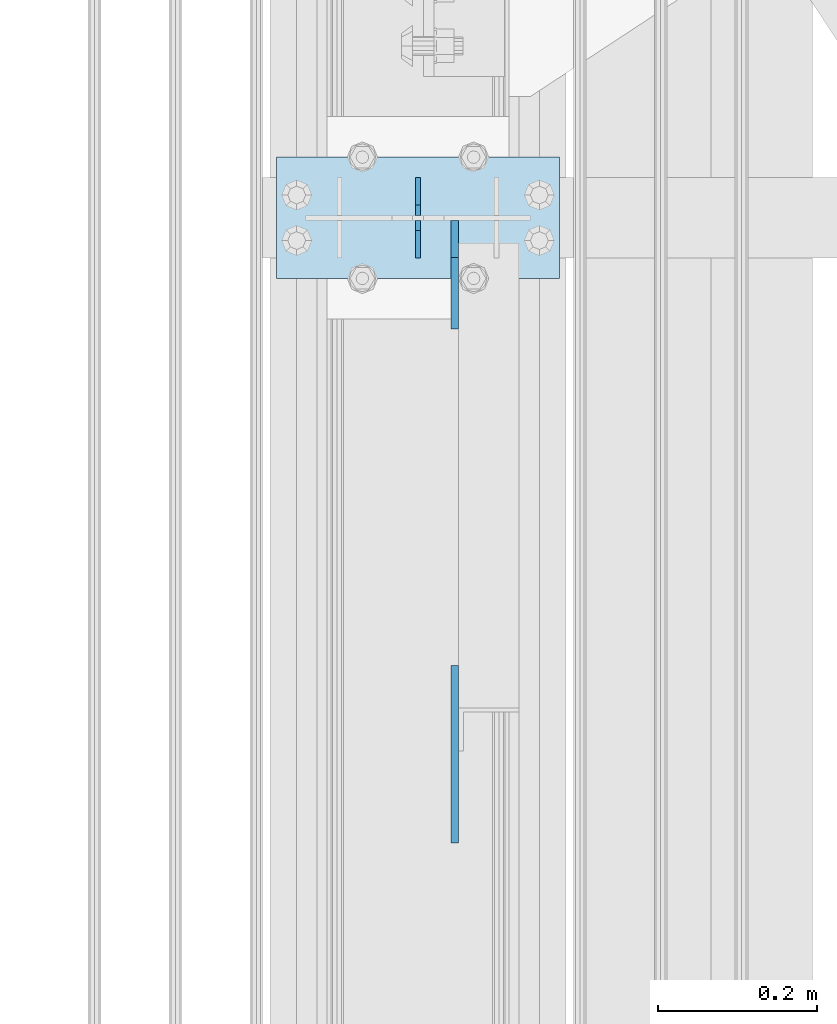
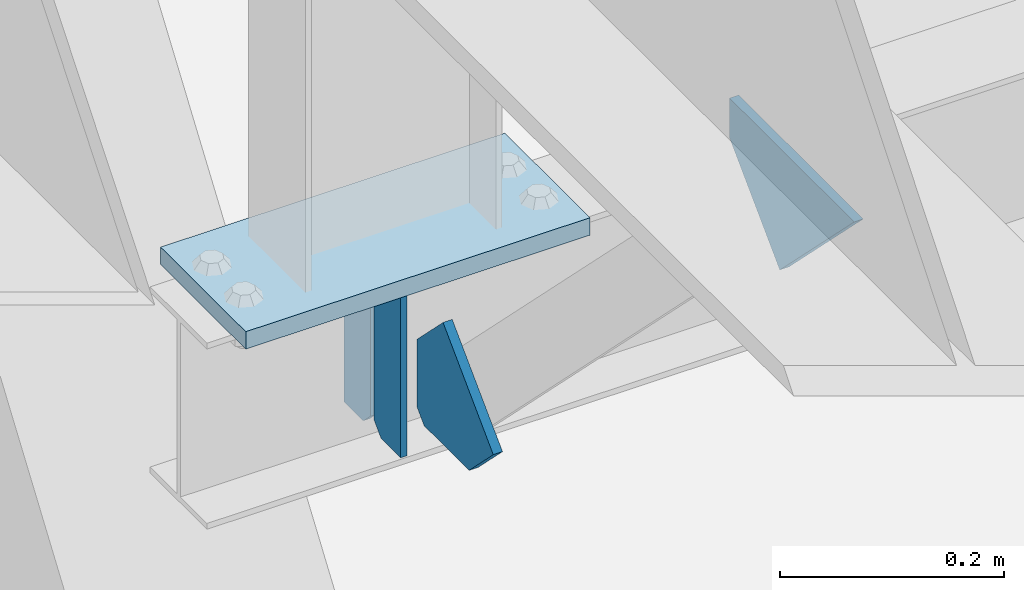
# One storey, part 3268 of 3843: 5 plates, 3 elements without a shape of their own.
"""IFC2X3 building model written with IfcOpenShell, lengths in millimetres."""

from ifc_helpers import new_model, si_unit, frame, origin_with_axes, place, context, subcontext, project, spatial, faceted_brep, material, type_object, element, aggregate, save


model = new_model("IFC2X3")

# Units and contexts
model_context = context("Model", 3, precision=1e-05, world=origin_with_axes())
body_context = subcontext(model_context, "Body", "Model", "MODEL_VIEW")
ifc_project = project(units=[si_unit("LENGTHUNIT", "METRE", prefix="MILLI"), si_unit("AREAUNIT", "SQUARE_METRE"), si_unit("VOLUMEUNIT", "CUBIC_METRE"), si_unit("MASSUNIT", "GRAM", prefix="KILO"), si_unit("TIMEUNIT", "SECOND"), si_unit("PLANEANGLEUNIT", "RADIAN"), si_unit("SOLIDANGLEUNIT", "STERADIAN"), si_unit("THERMODYNAMICTEMPERATUREUNIT", "DEGREE_CELSIUS"), si_unit("LUMINOUSINTENSITYUNIT", "LUMEN")], contexts=[model_context])

# Site, building, storey
site_placement = place(None, origin_with_axes())
site = spatial("IfcSite", under=ifc_project, at=site_placement, CompositionType="ELEMENT")
building_placement = place(site_placement, origin_with_axes())
building = spatial("IfcBuilding", under=site, at=building_placement, Name="Undefined", CompositionType="ELEMENT")
storey_placement = place(building_placement, origin_with_axes())
storey = spatial("IfcBuildingStorey", under=building, at=storey_placement, Name="Undefined", CompositionType="ELEMENT", Elevation=0.0)

# Assembly, plates
assembly_1_placement = place(storey_placement, origin_with_axes())
assembly_1 = element("IfcElementAssembly", 1, at=assembly_1_placement, inside=storey, Name="BEAM", AssemblyPlace="NOTDEFINED", PredefinedType="RIGID_FRAME")
ifc_material = material(Name="STEEL/A572-50")
plate_type_1 = type_object("IfcPlateType", PredefinedType="NOTDEFINED")
plate_1_placement = place(assembly_1_placement, frame((36576.0000030517, 57594.5, 41495.6625), z_axis=(0.0, 0.0, -1.0), x_axis=(0.0, -1.0, 0.0)))
plate_1 = element("IfcPlate", 2, at=plate_1_placement, type_object=plate_type_1, material=ifc_material, Name="PLATE", context=body_context, shape_type="Brep", body=[
    faceted_brep([(0.0, -3.17499999999927, 0.0), (0.0, -3.17500000000291, 187.324999999997), (0.0, 3.17500000000291, 187.324999999997), (0.0, 3.17499999999927, 0.0), (34.9250001907349, -3.17500000000291, 187.324999999997), (34.9250001907349, 3.17500000000291, 187.324999999997), (47.625, -3.17500000000291, 174.625000190732), (47.625, 3.17500000000291, 174.625000190732), (47.625, -3.17499999999927, 12.6999998092651), (47.625, 3.17499999999927, 12.6999998092651), (34.9250001907349, -3.17499999999927, 0.0), (34.9250001907349, 3.17499999999927, 0.0)], [[[0, 1, 2, 3]], [[1, 4, 5, 2]], [[4, 6, 7, 5]], [[6, 8, 9, 7]], [[8, 10, 11, 9]], [[10, 0, 3, 11]], [[5, 7, 9, 11, 3, 2]], [[10, 8, 6, 4, 1, 0]]]),
])
plate_2_placement = place(assembly_1_placement, frame((36576.0000030517, 57492.9, 41495.6625), z_axis=(0.0, 0.0, -1.0), x_axis=(0.0, 1.0, 0.0)))
plate_2 = element("IfcPlate", 3, at=plate_2_placement, type_object=plate_type_1, material=ifc_material, Name="PLATE", context=body_context, shape_type="Brep", body=[
    faceted_brep([(0.0, -3.17499999999927, 0.0), (0.0, -3.17500000000291, 187.324999999997), (0.0, 3.17500000000291, 187.324999999997), (0.0, 3.17499999999927, 0.0), (34.9250001907349, -3.17500000000291, 187.324999999997), (34.9250001907349, 3.17500000000291, 187.324999999997), (47.625, -3.17500000000291, 174.625000190732), (47.625, 3.17500000000291, 174.625000190732), (47.625, -3.17499999999927, 12.6999998092651), (47.625, 3.17499999999927, 12.6999998092651), (34.9250001907349, -3.17499999999927, 0.0), (34.9250001907349, 3.17499999999927, 0.0)], [[[0, 1, 2, 3]], [[1, 4, 5, 2]], [[4, 6, 7, 5]], [[6, 8, 9, 7]], [[8, 10, 11, 9]], [[10, 0, 3, 11]], [[5, 7, 9, 11, 3, 2]], [[10, 8, 6, 4, 1, 0]]]),
])

# Assembly, plate
assembly_2_placement = place(storey_placement, origin_with_axes())
assembly_2 = element("IfcElementAssembly", 4, at=assembly_2_placement, inside=storey, Name="POST", AssemblyPlace="NOTDEFINED", PredefinedType="RIGID_FRAME")
plate_type_2 = type_object("IfcPlateType", PredefinedType="NOTDEFINED")
plate_3_placement = place(assembly_2_placement, frame((36753.8000030518, 57467.5, 41513.125), z_axis=(-1.0, 0.0, 0.0), x_axis=(0.0, 1.0, 0.0)))
plate_3 = element("IfcPlate", 5, at=plate_3_placement, type_object=plate_type_2, material=ifc_material, Name="PLATE", context=body_context, shape_type="Brep", body=[
    faceted_brep([(0.0, -9.52500000000146, 0.0), (0.0, -9.52500000000146, 355.599999999999), (0.0, 9.52500000000146, 355.599999999999), (0.0, 9.52500000000146, 0.0), (152.399999999994, -9.52500000000146, 355.599999999999), (152.399999999994, 9.52500000000146, 355.599999999999), (152.400000000001, -9.52500000000146, 0.0), (152.400000000001, 9.52500000000146, 0.0)], [[[0, 1, 2, 3]], [[1, 4, 5, 2]], [[4, 6, 7, 5]], [[6, 0, 3, 7]], [[5, 7, 3, 2]], [[6, 4, 1, 0]]]),
])
aggregate(assembly_2, [plate_3])

assembly_3_placement = place(storey_placement, origin_with_axes())
assembly_3 = element("IfcElementAssembly", 6, at=assembly_3_placement, inside=storey, Name="BEAM", AssemblyPlace="NOTDEFINED", PredefinedType="RIGID_FRAME")
plate_type_3 = type_object("IfcPlateType", PredefinedType="NOTDEFINED")
plate_4_placement = place(assembly_3_placement, frame((36622.0375, 56758.4789773786, 41995.725), z_axis=(0.0, 0.707106781186548, 0.707106781186548), x_axis=(5.70000238222118e-08, 0.707106781186546, -0.707106781186546)))
plate_4 = element("IfcPlate", 7, at=plate_4_placement, type_object=plate_type_3, material=ifc_material, Name="PLATE", context=body_context, shape_type="Brep", body=[
    faceted_brep([(0.0, -4.76249999999709, 0.0), (157.726597423803, -4.76249999999709, 157.726601438866), (157.726597423803, 4.76249999999709, 157.726601438866), (0.0, 4.76249999999709, 0.0), (188.387110059113, -4.76249999999709, 127.066089584019), (188.387110059113, 4.76249999999709, 127.066089584019), (188.387111679331, -4.76249999999709, 1.09139364212751e-10), (188.387111679331, 4.76249999999709, 1.09139364212751e-10)], [[[0, 1, 2, 3]], [[1, 4, 5, 2]], [[4, 6, 7, 5]], [[6, 0, 3, 7]], [[5, 7, 3, 2]], [[6, 4, 1, 0]]]),
])
aggregate(assembly_3, [plate_4])

# Plate
plate_type_4 = type_object("IfcPlateType", PredefinedType="NOTDEFINED")
plate_5_placement = place(assembly_1_placement, frame((36622.0375, 57540.525, 41306.75), z_axis=(0.0, -1.0, 0.0), x_axis=(0.0, 0.0, 1.0)))
plate_5 = element("IfcPlate", 8, at=plate_5_placement, type_object=plate_type_4, material=ifc_material, Name="PLATE", context=body_context, shape_type="Brep", body=[
    faceted_brep([(0.0, -4.76250000000073, 12.6999998092651), (4.450703272596e-08, -4.76249999999709, 93.0710244828806), (4.450703272596e-08, 4.76249999999709, 93.0710244828806), (0.0, 4.76250000000073, 12.6999998092651), (43.3137807601452, -4.76249999999709, 136.384805065652), (43.3137807601452, 4.76249999999709, 136.384805065652), (133.209805202001, -4.76249999999709, 46.4887805392646), (133.209805202001, 4.76249999999709, 46.4887805392646), (86.7210245267561, -4.76249999999709, 0.0), (86.7210245267561, 4.76249999999709, 0.0), (12.6999998092651, -4.76250000000073, 0.0), (12.6999998092651, 4.76250000000073, 0.0)], [[[0, 1, 2, 3]], [[1, 4, 5, 2]], [[4, 6, 7, 5]], [[6, 8, 9, 7]], [[8, 10, 11, 9]], [[10, 0, 3, 11]], [[5, 7, 9, 11, 3, 2]], [[10, 8, 6, 4, 1, 0]]]),
])

aggregate(assembly_1, [plate_1, plate_2, plate_5])

save(model, "model.ifc")
